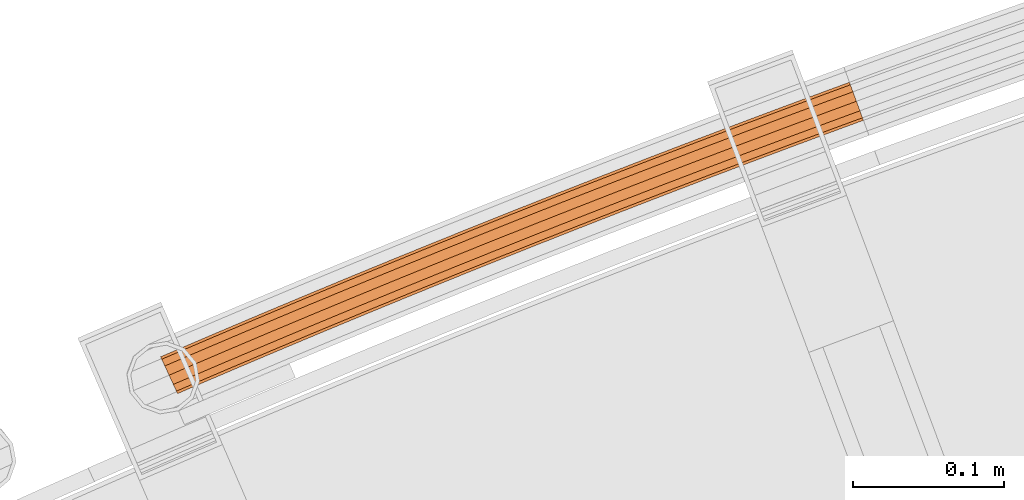
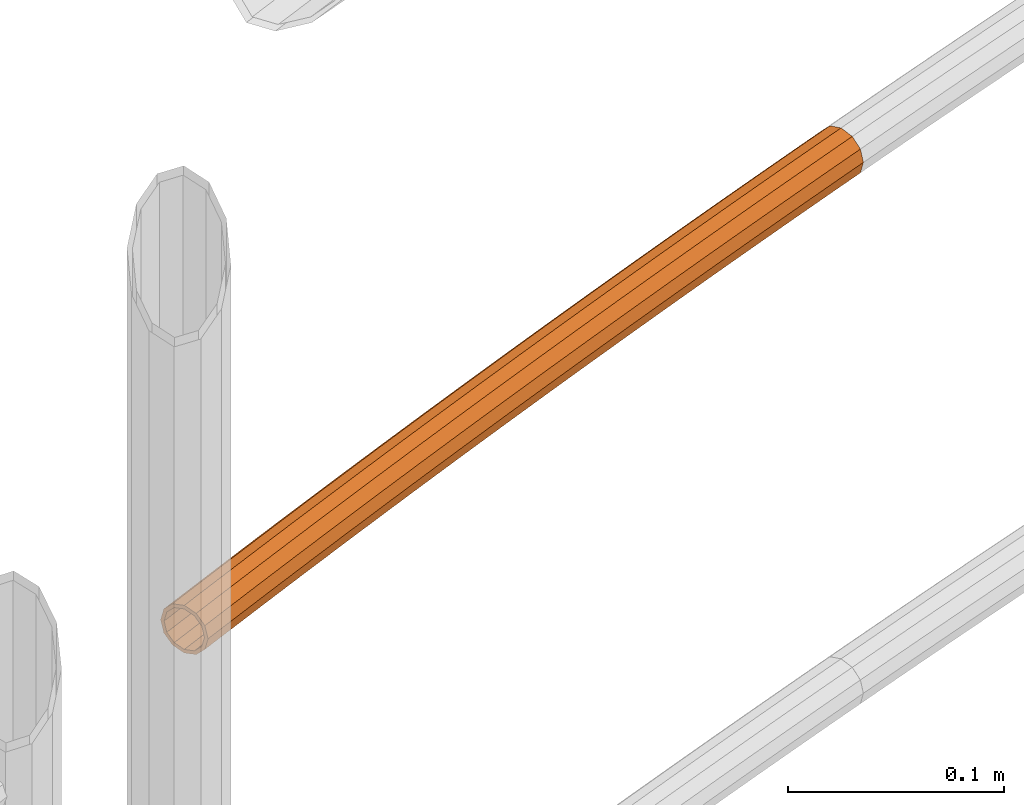
# One storey, part 100 of 126: 1 proxy.
"""IFC2X3 building model written with IfcOpenShell, lengths in millimetres."""

from ifc_helpers import new_model, si_unit, origin, origin_with_axes, place, context, project, spatial, faceted_brep, material, element, save


model = new_model("IFC2X3")

# Units and contexts
context_of_model_1 = context(None, 3, precision=0.1, world=origin())
context_of_model_2 = context(None, 3, precision=0.1, world=origin())
ifc_project = project(units=[si_unit("LENGTHUNIT", "METRE", prefix="MILLI"), si_unit("AREAUNIT", "SQUARE_METRE", prefix="CENTI"), si_unit("VOLUMEUNIT", "CUBIC_METRE", prefix="CENTI"), si_unit("MASSUNIT", "GRAM", prefix="KILO")], contexts=[context_of_model_1, context_of_model_2])

# Site, building, storey
site_placement = place(None, origin_with_axes())
site = spatial("IfcSite", under=ifc_project, at=site_placement, CompositionType="ELEMENT")
building_placement = place(site_placement, origin_with_axes())
building = spatial("IfcBuilding", under=site, at=building_placement, CompositionType="ELEMENT")
storey_placement = place(building_placement, origin_with_axes())
storey = spatial("IfcBuildingStorey", under=building, at=storey_placement, CompositionType="ELEMENT")

# Proxy
ifc_material = material(Name="S235JRG2")
proxy_placement = place(storey_placement, origin_with_axes())
element("IfcBuildingElementProxy", 1, at=proxy_placement, inside=storey, material=ifc_material, context=context_of_model_2, shape_type="Brep", body=[
    faceted_brep([(4502.0995, 16162.147, 11838.155), (4502.8105, 16160.491, 11831.43), (4492.1373, 16155.886, 11831.43), (4491.383, 16157.523, 11838.155), (4504.753, 16155.968, 11826.507), (4494.1982, 16151.413, 11826.507), (4507.4066, 16149.788, 11824.705), (4497.0135, 16145.304, 11824.705), (4510.0602, 16143.609, 11826.507), (4499.8288, 16139.194, 11826.507), (4512.0027, 16139.085, 11831.43), (4501.8897, 16134.722, 11831.43), (4512.7138, 16137.43, 11838.155), (4502.644, 16133.085, 11838.155), (4512.0027, 16139.085, 11844.88), (4501.8897, 16134.722, 11844.88), (4510.0602, 16143.609, 11849.803), (4499.8288, 16139.194, 11849.803), (4507.4066, 16149.788, 11851.605), (4497.0135, 16145.304, 11851.605), (4504.753, 16155.968, 11849.803), (4494.1982, 16151.413, 11849.803), (4502.8105, 16160.491, 11844.88), (4492.1373, 16155.886, 11844.88), (4502.8886, 16160.309, 11838.155), (4503.4939, 16158.9, 11843.88), (4492.8624, 16154.312, 11843.88), (4492.2202, 16155.706, 11838.155), (4505.1476, 16155.049, 11848.071), (4494.6169, 16150.505, 11848.071), (4507.4066, 16149.788, 11849.605), (4497.0135, 16145.304, 11849.605), (4509.6656, 16144.528, 11848.071), (4499.4101, 16140.103, 11848.071), (4511.3193, 16140.677, 11843.88), (4501.1646, 16136.295, 11843.88), (4511.9246, 16139.267, 11838.155), (4501.8068, 16134.902, 11838.155), (4511.3193, 16140.677, 11832.43), (4501.1646, 16136.295, 11832.43), (4509.6656, 16144.528, 11828.239), (4499.4101, 16140.103, 11828.239), (4507.4066, 16149.788, 11826.705), (4497.0135, 16145.304, 11826.705), (4505.1476, 16155.049, 11828.239), (4494.6169, 16150.505, 11828.239), (4503.4939, 16158.9, 11832.43), (4492.8624, 16154.312, 11832.43), (4530.5945, 16174.325, 11838.155), (4531.2998, 16172.666, 11831.43), (4533.2265, 16168.136, 11826.507), (4535.8585, 16161.948, 11824.705), (4538.4905, 16155.759, 11826.507), (4540.4173, 16151.229, 11831.43), (4541.1225, 16149.57, 11838.155), (4540.4173, 16151.229, 11844.88), (4538.4905, 16155.759, 11849.803), (4535.8585, 16161.948, 11851.605), (4533.2265, 16168.136, 11849.803), (4531.2998, 16172.666, 11844.88), (4531.3773, 16172.484, 11838.155), (4531.9777, 16171.073, 11843.88), (4533.6179, 16167.216, 11848.071), (4535.8585, 16161.948, 11849.605), (4538.0992, 16156.679, 11848.071), (4539.7394, 16152.823, 11843.88), (4540.3398, 16151.411, 11838.155), (4539.7394, 16152.823, 11832.43), (4538.0992, 16156.679, 11828.239), (4535.8585, 16161.948, 11826.705), (4533.6179, 16167.216, 11828.239), (4531.9777, 16171.073, 11832.43), (4559.132, 16186.403, 11838.155), (4559.8314, 16184.742, 11831.43), (4561.7424, 16180.205, 11826.507), (4564.3527, 16174.007, 11824.705), (4566.9631, 16167.81, 11826.507), (4568.874, 16163.273, 11831.43), (4569.5735, 16161.612, 11838.155), (4568.874, 16163.273, 11844.88), (4566.9631, 16167.81, 11849.803), (4564.3527, 16174.007, 11851.605), (4561.7424, 16180.205, 11849.803), (4559.8314, 16184.742, 11844.88), (4559.9083, 16184.56, 11838.155), (4560.5037, 16183.146, 11843.88), (4562.1305, 16179.284, 11848.071), (4564.3527, 16174.007, 11849.605), (4566.5749, 16168.731, 11848.071), (4568.2017, 16164.869, 11843.88), (4568.7972, 16163.455, 11838.155), (4568.2017, 16164.869, 11832.43), (4566.5749, 16168.731, 11828.239), (4564.3527, 16174.007, 11826.705), (4562.1305, 16179.284, 11828.239), (4560.5037, 16183.146, 11832.43), (4587.7114, 16198.381, 11838.155), (4588.405, 16196.718, 11831.43), (4590.3001, 16192.174, 11826.507), (4592.8888, 16185.968, 11824.705), (4595.4776, 16179.761, 11826.507), (4597.3726, 16175.217, 11831.43), (4598.0663, 16173.554, 11838.155), (4597.3726, 16175.217, 11844.88), (4595.4776, 16179.761, 11849.803), (4592.8888, 16185.968, 11851.605), (4590.3001, 16192.174, 11849.803), (4588.405, 16196.718, 11844.88), (4588.4813, 16196.535, 11838.155), (4589.0718, 16195.12, 11843.88), (4590.6851, 16191.252, 11848.071), (4592.8888, 16185.968, 11849.605), (4595.0926, 16180.684, 11848.071), (4596.7059, 16176.816, 11843.88), (4597.2964, 16175.4, 11838.155), (4596.7059, 16176.816, 11832.43), (4595.0926, 16180.684, 11828.239), (4592.8888, 16185.968, 11826.705), (4590.6851, 16191.252, 11828.239), (4589.0718, 16195.12, 11832.43), (4616.3325, 16210.26, 11838.155), (4617.0203, 16208.594, 11831.43), (4618.8995, 16204.044, 11826.507), (4621.4665, 16197.828, 11824.705), (4624.0336, 16191.613, 11826.507), (4625.9128, 16187.062, 11831.43), (4626.6006, 16185.397, 11838.155), (4625.9128, 16187.062, 11844.88), (4624.0336, 16191.613, 11849.803), (4621.4665, 16197.828, 11851.605), (4618.8995, 16204.044, 11849.803), (4617.0203, 16208.594, 11844.88), (4617.0959, 16208.411, 11838.155), (4617.6814, 16206.994, 11843.88), (4619.2812, 16203.12, 11848.071), (4621.4665, 16197.828, 11849.605), (4623.6519, 16192.537, 11848.071), (4625.2516, 16188.663, 11843.88), (4625.8372, 16187.245, 11838.155), (4625.2516, 16188.663, 11832.43), (4623.6519, 16192.537, 11828.239), (4621.4665, 16197.828, 11826.705), (4619.2812, 16203.12, 11828.239), (4617.6814, 16206.994, 11832.43), (4644.9948, 16222.039, 11838.155), (4645.6768, 16220.371, 11831.43), (4647.5401, 16215.814, 11826.507), (4650.0855, 16209.589, 11824.705), (4652.6308, 16203.365, 11826.507), (4654.4941, 16198.808, 11831.43), (4655.1761, 16197.14, 11838.155), (4654.4941, 16198.808, 11844.88), (4652.6308, 16203.365, 11849.803), (4650.0855, 16209.589, 11851.605), (4647.5401, 16215.814, 11849.803), (4645.6768, 16220.371, 11844.88), (4645.7518, 16220.187, 11838.155), (4646.3324, 16218.768, 11843.88), (4647.9186, 16214.888, 11848.071), (4650.0855, 16209.589, 11849.605), (4652.2523, 16204.29, 11848.071), (4653.8385, 16200.411, 11843.88), (4654.4191, 16198.991, 11838.155), (4653.8385, 16200.411, 11832.43), (4652.2523, 16204.29, 11828.239), (4650.0855, 16209.589, 11826.705), (4647.9186, 16214.888, 11828.239), (4646.3324, 16218.768, 11832.43), (4673.6981, 16233.717, 11838.155), (4674.3743, 16232.047, 11831.43), (4676.2217, 16227.484, 11826.507), (4678.7453, 16221.25, 11824.705), (4681.2688, 16215.017, 11826.507), (4683.1162, 16210.453, 11831.43), (4683.7924, 16208.783, 11838.155), (4683.1162, 16210.453, 11844.88), (4681.2688, 16215.017, 11849.803), (4678.7453, 16221.25, 11851.605), (4676.2217, 16227.484, 11849.803), (4674.3743, 16232.047, 11844.88), (4674.4486, 16231.863, 11838.155), (4675.0242, 16230.441, 11843.88), (4676.5969, 16226.557, 11848.071), (4678.7453, 16221.25, 11849.605), (4680.8936, 16215.943, 11848.071), (4682.4663, 16212.059, 11843.88), (4683.0419, 16210.637, 11838.155), (4682.4663, 16212.059, 11832.43), (4680.8936, 16215.943, 11828.239), (4678.7453, 16221.25, 11826.705), (4676.5969, 16226.557, 11828.239), (4675.0242, 16230.441, 11832.43), (4702.442, 16245.295, 11838.155), (4703.1123, 16243.623, 11831.43), (4704.9438, 16239.053, 11826.507), (4707.4456, 16232.811, 11824.705), (4709.9474, 16226.568, 11826.507), (4711.7789, 16221.999, 11831.43), (4712.4492, 16220.326, 11838.155), (4711.7789, 16221.999, 11844.88), (4709.9474, 16226.568, 11849.803), (4707.4456, 16232.811, 11851.605), (4704.9438, 16239.053, 11849.803), (4703.1123, 16243.623, 11844.88), (4703.186, 16243.439, 11838.155), (4703.7567, 16242.015, 11843.88), (4705.3158, 16238.125, 11848.071), (4707.4456, 16232.811, 11849.605), (4709.5754, 16227.497, 11848.071), (4711.1345, 16223.607, 11843.88), (4711.7052, 16222.183, 11838.155), (4711.1345, 16223.607, 11832.43), (4709.5754, 16227.497, 11828.239), (4707.4456, 16232.811, 11826.705), (4705.3158, 16238.125, 11828.239), (4703.7567, 16242.015, 11832.43), (4731.2261, 16256.773, 11838.155), (4731.8906, 16255.098, 11831.43), (4733.7061, 16250.522, 11826.507), (4736.1861, 16244.271, 11824.705), (4738.6661, 16238.02, 11826.507), (4740.4816, 16233.444, 11831.43), (4741.1461, 16231.769, 11838.155), (4740.4816, 16233.444, 11844.88), (4738.6661, 16238.02, 11849.803), (4736.1861, 16244.271, 11851.605), (4733.7061, 16250.522, 11849.803), (4731.8906, 16255.098, 11844.88), (4731.9636, 16254.914, 11838.155), (4732.5293, 16253.488, 11843.88), (4734.0749, 16249.593, 11848.071), (4736.1861, 16244.271, 11849.605), (4738.2973, 16238.95, 11848.071), (4739.8429, 16235.054, 11843.88), (4740.4086, 16233.628, 11838.155), (4739.8429, 16235.054, 11832.43), (4738.2973, 16238.95, 11828.239), (4736.1861, 16244.271, 11826.705), (4734.0749, 16249.593, 11828.239), (4732.5293, 16253.488, 11832.43), (4760.0501, 16268.151, 11838.155), (4760.7088, 16266.473, 11831.43), (4762.5083, 16261.891, 11826.507), (4764.9664, 16255.631, 11824.705), (4767.4246, 16249.372, 11826.507), (4769.2241, 16244.789, 11831.43), (4769.8828, 16243.112, 11838.155), (4769.2241, 16244.789, 11844.88), (4767.4246, 16249.372, 11849.803), (4764.9664, 16255.631, 11851.605), (4762.5083, 16261.891, 11849.803), (4760.7088, 16266.473, 11844.88), (4760.7812, 16266.289, 11838.155), (4761.3419, 16264.861, 11843.88), (4762.8738, 16260.96, 11848.071), (4764.9664, 16255.631, 11849.605), (4767.0591, 16250.303, 11848.071), (4768.591, 16246.402, 11843.88), (4769.1517, 16244.974, 11838.155), (4768.591, 16246.402, 11832.43), (4767.0591, 16250.303, 11828.239), (4764.9664, 16255.631, 11826.705), (4762.8738, 16260.96, 11828.239), (4761.3419, 16264.861, 11832.43), (4788.9136, 16279.427, 11838.155), (4789.5665, 16277.748, 11831.43), (4791.35, 16273.159, 11826.507), (4793.7863, 16266.891, 11824.705), (4796.2226, 16260.623, 11826.507), (4798.0061, 16256.034, 11831.43), (4798.6589, 16254.354, 11838.155), (4798.0061, 16256.034, 11844.88), (4796.2226, 16260.623, 11849.803), (4793.7863, 16266.891, 11851.605), (4791.35, 16273.159, 11849.803), (4789.5665, 16277.748, 11844.88), (4789.6382, 16277.563, 11838.155), (4790.1939, 16276.133, 11843.88), (4791.7122, 16272.227, 11848.071), (4793.7863, 16266.891, 11849.605), (4795.8603, 16261.555, 11848.071), (4797.3786, 16257.648, 11843.88), (4797.9343, 16256.219, 11838.155), (4797.3786, 16257.648, 11832.43), (4795.8603, 16261.555, 11828.239), (4793.7863, 16266.891, 11826.705), (4791.7122, 16272.227, 11828.239), (4790.1939, 16276.133, 11832.43), (4817.8164, 16290.603, 11838.155), (4818.4633, 16288.921, 11831.43), (4820.2308, 16284.326, 11826.507), (4822.6452, 16278.05, 11824.705), (4825.0596, 16271.773, 11826.507), (4826.8271, 16267.178, 11831.43), (4827.474, 16265.496, 11838.155), (4826.8271, 16267.178, 11844.88), (4825.0596, 16271.773, 11849.803), (4822.6452, 16278.05, 11851.605), (4820.2308, 16284.326, 11849.803), (4818.4633, 16288.921, 11844.88), (4818.5344, 16288.737, 11838.155), (4819.0852, 16287.305, 11843.88), (4820.5898, 16283.393, 11848.071), (4822.6452, 16278.05, 11849.605), (4824.7006, 16272.707, 11848.071), (4826.2052, 16268.795, 11843.88), (4826.756, 16267.363, 11838.155), (4826.2052, 16268.795, 11832.43), (4824.7006, 16272.707, 11828.239), (4822.6452, 16278.05, 11826.705), (4820.5898, 16283.393, 11828.239), (4819.0852, 16287.305, 11832.43), (4846.758, 16301.678, 11838.155), (4847.399, 16299.994, 11831.43), (4849.1504, 16295.393, 11826.507), (4851.5429, 16289.108, 11824.705), (4853.9354, 16282.823, 11826.507), (4855.6868, 16278.222, 11831.43), (4856.3279, 16276.538, 11838.155), (4855.6868, 16278.222, 11844.88), (4853.9354, 16282.823, 11849.803), (4851.5429, 16289.108, 11851.605), (4849.1504, 16295.393, 11849.803), (4847.399, 16299.994, 11844.88), (4847.4695, 16299.809, 11838.155), (4848.0152, 16298.375, 11843.88), (4849.5062, 16294.458, 11848.071), (4851.5429, 16289.108, 11849.605), (4853.5797, 16283.757, 11848.071), (4855.0706, 16279.841, 11843.88), (4855.6164, 16278.407, 11838.155), (4855.0706, 16279.841, 11832.43), (4853.5797, 16283.757, 11828.239), (4851.5429, 16289.108, 11826.705), (4849.5062, 16294.458, 11828.239), (4848.0152, 16298.375, 11832.43), (4875.738, 16312.652, 11838.155), (4876.3732, 16310.966, 11831.43), (4878.1085, 16306.358, 11826.507), (4880.4791, 16300.065, 11824.705), (4882.8496, 16293.772, 11826.507), (4884.585, 16289.165, 11831.43), (4885.2201, 16287.478, 11838.155), (4884.585, 16289.165, 11844.88), (4882.8496, 16293.772, 11849.803), (4880.4791, 16300.065, 11851.605), (4878.1085, 16306.358, 11849.803), (4876.3732, 16310.966, 11844.88), (4876.443, 16310.78, 11838.155), (4876.9837, 16309.345, 11843.88), (4878.461, 16305.423, 11848.071), (4880.4791, 16300.065, 11849.605), (4882.4971, 16294.708, 11848.071), (4883.9744, 16290.786, 11843.88), (4884.5151, 16289.35, 11838.155), (4883.9744, 16290.786, 11832.43), (4882.4971, 16294.708, 11828.239), (4880.4791, 16300.065, 11826.705), (4878.461, 16305.423, 11828.239), (4876.9837, 16309.345, 11832.43), (4904.7562, 16323.524, 11838.155), (4905.3855, 16321.836, 11831.43), (4907.1047, 16317.223, 11826.507), (4909.4533, 16310.921, 11824.705), (4911.8018, 16304.62, 11826.507), (4913.5211, 16300.007, 11831.43), (4914.1504, 16298.318, 11838.155), (4913.5211, 16300.007, 11844.88), (4911.8018, 16304.62, 11849.803), (4909.4533, 16310.921, 11851.605), (4907.1047, 16317.223, 11849.803), (4905.3855, 16321.836, 11844.88), (4905.4546, 16321.65, 11838.155), (4905.9904, 16320.213, 11843.88), (4907.454, 16316.286, 11848.071), (4909.4533, 16310.921, 11849.605), (4911.4526, 16305.557, 11848.071), (4912.9162, 16301.629, 11843.88), (4913.4519, 16300.192, 11838.155), (4912.9162, 16301.629, 11832.43), (4911.4526, 16305.557, 11828.239), (4909.4533, 16310.921, 11826.705), (4907.454, 16316.286, 11828.239), (4905.9904, 16320.213, 11832.43), (4933.8121, 16334.296, 11838.155), (4934.4355, 16332.605, 11831.43), (4936.1387, 16327.986, 11826.507), (4938.4652, 16321.676, 11824.705), (4940.7918, 16315.366, 11826.507), (4942.4949, 16310.747, 11831.43), (4943.1183, 16309.057, 11838.155), (4942.4949, 16310.747, 11844.88), (4940.7918, 16315.366, 11849.803), (4938.4652, 16321.676, 11851.605), (4936.1387, 16327.986, 11849.803), (4934.4355, 16332.605, 11844.88), (4934.504, 16332.419, 11838.155), (4935.0347, 16330.98, 11843.88), (4936.4846, 16327.048, 11848.071), (4938.4652, 16321.676, 11849.605), (4940.4458, 16316.305, 11848.071), (4941.8957, 16312.372, 11843.88), (4942.4264, 16310.933, 11838.155), (4941.8957, 16312.372, 11832.43), (4940.4458, 16316.305, 11828.239), (4938.4652, 16321.676, 11826.705), (4936.4846, 16327.048, 11828.239), (4935.0347, 16330.98, 11832.43), (4948.3572, 16339.63, 11838.155), (4948.9777, 16337.938, 11831.43), (4950.6729, 16333.316, 11826.507), (4952.9886, 16327.002, 11824.705), (4955.3043, 16320.689, 11826.507), (4956.9995, 16316.067, 11831.43), (4957.62, 16314.375, 11838.155), (4956.9995, 16316.067, 11844.88), (4955.3043, 16320.689, 11849.803), (4952.9886, 16327.002, 11851.605), (4950.6729, 16333.316, 11849.803), (4948.9777, 16337.938, 11844.88), (4949.0459, 16337.752, 11838.155), (4949.5741, 16336.312, 11843.88), (4951.0173, 16332.377, 11848.071), (4952.9886, 16327.002, 11849.605), (4954.96, 16321.627, 11848.071), (4956.4031, 16317.693, 11843.88), (4956.9313, 16316.253, 11838.155), (4956.4031, 16317.693, 11832.43), (4954.96, 16321.627, 11828.239), (4952.9886, 16327.002, 11826.705), (4951.0173, 16332.377, 11828.239), (4949.5741, 16336.312, 11832.43)], [[[0, 1, 2, 3]], [[1, 4, 5, 2]], [[4, 6, 7, 5]], [[6, 8, 9, 7]], [[8, 10, 11, 9]], [[10, 12, 13, 11]], [[12, 14, 15, 13]], [[14, 16, 17, 15]], [[16, 18, 19, 17]], [[18, 20, 21, 19]], [[20, 22, 23, 21]], [[0, 3, 23, 22]], [[24, 25, 26, 27]], [[25, 28, 29, 26]], [[28, 30, 31, 29]], [[30, 32, 33, 31]], [[32, 34, 35, 33]], [[34, 36, 37, 35]], [[36, 38, 39, 37]], [[38, 40, 41, 39]], [[40, 42, 43, 41]], [[42, 44, 45, 43]], [[44, 46, 47, 45]], [[24, 27, 47, 46]], [[0, 48, 49, 1]], [[1, 49, 50, 4]], [[4, 50, 51, 6]], [[6, 51, 52, 8]], [[8, 52, 53, 10]], [[10, 53, 54, 12]], [[12, 54, 55, 14]], [[14, 55, 56, 16]], [[16, 56, 57, 18]], [[18, 57, 58, 20]], [[20, 58, 59, 22]], [[22, 59, 48, 0]], [[24, 60, 61, 25]], [[25, 61, 62, 28]], [[28, 62, 63, 30]], [[30, 63, 64, 32]], [[32, 64, 65, 34]], [[34, 65, 66, 36]], [[36, 66, 67, 38]], [[38, 67, 68, 40]], [[40, 68, 69, 42]], [[42, 69, 70, 44]], [[44, 70, 71, 46]], [[46, 71, 60, 24]], [[48, 72, 73, 49]], [[49, 73, 74, 50]], [[50, 74, 75, 51]], [[51, 75, 76, 52]], [[52, 76, 77, 53]], [[53, 77, 78, 54]], [[54, 78, 79, 55]], [[55, 79, 80, 56]], [[56, 80, 81, 57]], [[57, 81, 82, 58]], [[58, 82, 83, 59]], [[59, 83, 72, 48]], [[60, 84, 85, 61]], [[61, 85, 86, 62]], [[62, 86, 87, 63]], [[63, 87, 88, 64]], [[64, 88, 89, 65]], [[65, 89, 90, 66]], [[66, 90, 91, 67]], [[67, 91, 92, 68]], [[68, 92, 93, 69]], [[69, 93, 94, 70]], [[70, 94, 95, 71]], [[71, 95, 84, 60]], [[72, 96, 97, 73]], [[73, 97, 98, 74]], [[74, 98, 99, 75]], [[75, 99, 100, 76]], [[76, 100, 101, 77]], [[77, 101, 102, 78]], [[78, 102, 103, 79]], [[79, 103, 104, 80]], [[80, 104, 105, 81]], [[81, 105, 106, 82]], [[82, 106, 107, 83]], [[83, 107, 96, 72]], [[84, 108, 109, 85]], [[85, 109, 110, 86]], [[86, 110, 111, 87]], [[87, 111, 112, 88]], [[88, 112, 113, 89]], [[89, 113, 114, 90]], [[90, 114, 115, 91]], [[91, 115, 116, 92]], [[92, 116, 117, 93]], [[93, 117, 118, 94]], [[94, 118, 119, 95]], [[95, 119, 108, 84]], [[96, 120, 121, 97]], [[97, 121, 122, 98]], [[98, 122, 123, 99]], [[99, 123, 124, 100]], [[100, 124, 125, 101]], [[101, 125, 126, 102]], [[102, 126, 127, 103]], [[103, 127, 128, 104]], [[104, 128, 129, 105]], [[105, 129, 130, 106]], [[106, 130, 131, 107]], [[107, 131, 120, 96]], [[108, 132, 133, 109]], [[109, 133, 134, 110]], [[110, 134, 135, 111]], [[111, 135, 136, 112]], [[112, 136, 137, 113]], [[113, 137, 138, 114]], [[114, 138, 139, 115]], [[115, 139, 140, 116]], [[116, 140, 141, 117]], [[117, 141, 142, 118]], [[118, 142, 143, 119]], [[119, 143, 132, 108]], [[120, 144, 145, 121]], [[121, 145, 146, 122]], [[122, 146, 147, 123]], [[123, 147, 148, 124]], [[124, 148, 149, 125]], [[125, 149, 150, 126]], [[126, 150, 151, 127]], [[127, 151, 152, 128]], [[128, 152, 153, 129]], [[129, 153, 154, 130]], [[130, 154, 155, 131]], [[131, 155, 144, 120]], [[132, 156, 157, 133]], [[133, 157, 158, 134]], [[134, 158, 159, 135]], [[135, 159, 160, 136]], [[136, 160, 161, 137]], [[137, 161, 162, 138]], [[138, 162, 163, 139]], [[139, 163, 164, 140]], [[140, 164, 165, 141]], [[141, 165, 166, 142]], [[142, 166, 167, 143]], [[143, 167, 156, 132]], [[144, 168, 169, 145]], [[145, 169, 170, 146]], [[146, 170, 171, 147]], [[147, 171, 172, 148]], [[148, 172, 173, 149]], [[149, 173, 174, 150]], [[150, 174, 175, 151]], [[151, 175, 176, 152]], [[152, 176, 177, 153]], [[153, 177, 178, 154]], [[154, 178, 179, 155]], [[155, 179, 168, 144]], [[156, 180, 181, 157]], [[157, 181, 182, 158]], [[158, 182, 183, 159]], [[159, 183, 184, 160]], [[160, 184, 185, 161]], [[161, 185, 186, 162]], [[162, 186, 187, 163]], [[163, 187, 188, 164]], [[164, 188, 189, 165]], [[165, 189, 190, 166]], [[166, 190, 191, 167]], [[167, 191, 180, 156]], [[168, 192, 193, 169]], [[169, 193, 194, 170]], [[170, 194, 195, 171]], [[171, 195, 196, 172]], [[172, 196, 197, 173]], [[173, 197, 198, 174]], [[174, 198, 199, 175]], [[175, 199, 200, 176]], [[176, 200, 201, 177]], [[177, 201, 202, 178]], [[178, 202, 203, 179]], [[179, 203, 192, 168]], [[180, 204, 205, 181]], [[181, 205, 206, 182]], [[182, 206, 207, 183]], [[183, 207, 208, 184]], [[184, 208, 209, 185]], [[185, 209, 210, 186]], [[186, 210, 211, 187]], [[187, 211, 212, 188]], [[188, 212, 213, 189]], [[189, 213, 214, 190]], [[190, 214, 215, 191]], [[191, 215, 204, 180]], [[192, 216, 217, 193]], [[193, 217, 218, 194]], [[194, 218, 219, 195]], [[195, 219, 220, 196]], [[196, 220, 221, 197]], [[197, 221, 222, 198]], [[198, 222, 223, 199]], [[199, 223, 224, 200]], [[200, 224, 225, 201]], [[201, 225, 226, 202]], [[202, 226, 227, 203]], [[203, 227, 216, 192]], [[204, 228, 229, 205]], [[205, 229, 230, 206]], [[206, 230, 231, 207]], [[207, 231, 232, 208]], [[208, 232, 233, 209]], [[209, 233, 234, 210]], [[210, 234, 235, 211]], [[211, 235, 236, 212]], [[212, 236, 237, 213]], [[213, 237, 238, 214]], [[214, 238, 239, 215]], [[215, 239, 228, 204]], [[216, 240, 241, 217]], [[217, 241, 242, 218]], [[218, 242, 243, 219]], [[219, 243, 244, 220]], [[220, 244, 245, 221]], [[221, 245, 246, 222]], [[222, 246, 247, 223]], [[223, 247, 248, 224]], [[224, 248, 249, 225]], [[225, 249, 250, 226]], [[226, 250, 251, 227]], [[227, 251, 240, 216]], [[228, 252, 253, 229]], [[229, 253, 254, 230]], [[230, 254, 255, 231]], [[231, 255, 256, 232]], [[232, 256, 257, 233]], [[233, 257, 258, 234]], [[234, 258, 259, 235]], [[235, 259, 260, 236]], [[236, 260, 261, 237]], [[237, 261, 262, 238]], [[238, 262, 263, 239]], [[239, 263, 252, 228]], [[240, 264, 265, 241]], [[241, 265, 266, 242]], [[242, 266, 267, 243]], [[243, 267, 268, 244]], [[244, 268, 269, 245]], [[245, 269, 270, 246]], [[246, 270, 271, 247]], [[247, 271, 272, 248]], [[248, 272, 273, 249]], [[249, 273, 274, 250]], [[250, 274, 275, 251]], [[251, 275, 264, 240]], [[252, 276, 277, 253]], [[253, 277, 278, 254]], [[254, 278, 279, 255]], [[255, 279, 280, 256]], [[256, 280, 281, 257]], [[257, 281, 282, 258]], [[258, 282, 283, 259]], [[259, 283, 284, 260]], [[260, 284, 285, 261]], [[261, 285, 286, 262]], [[262, 286, 287, 263]], [[263, 287, 276, 252]], [[264, 288, 289, 265]], [[265, 289, 290, 266]], [[266, 290, 291, 267]], [[267, 291, 292, 268]], [[268, 292, 293, 269]], [[269, 293, 294, 270]], [[270, 294, 295, 271]], [[271, 295, 296, 272]], [[272, 296, 297, 273]], [[273, 297, 298, 274]], [[274, 298, 299, 275]], [[275, 299, 288, 264]], [[276, 300, 301, 277]], [[277, 301, 302, 278]], [[278, 302, 303, 279]], [[279, 303, 304, 280]], [[280, 304, 305, 281]], [[281, 305, 306, 282]], [[282, 306, 307, 283]], [[283, 307, 308, 284]], [[284, 308, 309, 285]], [[285, 309, 310, 286]], [[286, 310, 311, 287]], [[287, 311, 300, 276]], [[288, 312, 313, 289]], [[289, 313, 314, 290]], [[290, 314, 315, 291]], [[291, 315, 316, 292]], [[292, 316, 317, 293]], [[293, 317, 318, 294]], [[294, 318, 319, 295]], [[295, 319, 320, 296]], [[296, 320, 321, 297]], [[297, 321, 322, 298]], [[298, 322, 323, 299]], [[299, 323, 312, 288]], [[300, 324, 325, 301]], [[301, 325, 326, 302]], [[302, 326, 327, 303]], [[303, 327, 328, 304]], [[304, 328, 329, 305]], [[305, 329, 330, 306]], [[306, 330, 331, 307]], [[307, 331, 332, 308]], [[308, 332, 333, 309]], [[309, 333, 334, 310]], [[310, 334, 335, 311]], [[311, 335, 324, 300]], [[312, 336, 337, 313]], [[313, 337, 338, 314]], [[314, 338, 339, 315]], [[315, 339, 340, 316]], [[316, 340, 341, 317]], [[317, 341, 342, 318]], [[318, 342, 343, 319]], [[319, 343, 344, 320]], [[320, 344, 345, 321]], [[321, 345, 346, 322]], [[322, 346, 347, 323]], [[323, 347, 336, 312]], [[324, 348, 349, 325]], [[325, 349, 350, 326]], [[326, 350, 351, 327]], [[327, 351, 352, 328]], [[328, 352, 353, 329]], [[329, 353, 354, 330]], [[330, 354, 355, 331]], [[331, 355, 356, 332]], [[332, 356, 357, 333]], [[333, 357, 358, 334]], [[334, 358, 359, 335]], [[335, 359, 348, 324]], [[336, 360, 361, 337]], [[337, 361, 362, 338]], [[338, 362, 363, 339]], [[339, 363, 364, 340]], [[340, 364, 365, 341]], [[341, 365, 366, 342]], [[342, 366, 367, 343]], [[343, 367, 368, 344]], [[344, 368, 369, 345]], [[345, 369, 370, 346]], [[346, 370, 371, 347]], [[347, 371, 360, 336]], [[348, 372, 373, 349]], [[349, 373, 374, 350]], [[350, 374, 375, 351]], [[351, 375, 376, 352]], [[352, 376, 377, 353]], [[353, 377, 378, 354]], [[354, 378, 379, 355]], [[355, 379, 380, 356]], [[356, 380, 381, 357]], [[357, 381, 382, 358]], [[358, 382, 383, 359]], [[359, 383, 372, 348]], [[360, 384, 385, 361]], [[361, 385, 386, 362]], [[362, 386, 387, 363]], [[363, 387, 388, 364]], [[364, 388, 389, 365]], [[365, 389, 390, 366]], [[366, 390, 391, 367]], [[367, 391, 392, 368]], [[368, 392, 393, 369]], [[369, 393, 394, 370]], [[370, 394, 395, 371]], [[371, 395, 384, 360]], [[372, 396, 397, 373]], [[373, 397, 398, 374]], [[374, 398, 399, 375]], [[375, 399, 400, 376]], [[376, 400, 401, 377]], [[377, 401, 402, 378]], [[378, 402, 403, 379]], [[379, 403, 404, 380]], [[380, 404, 405, 381]], [[381, 405, 406, 382]], [[382, 406, 407, 383]], [[383, 407, 396, 372]], [[384, 408, 409, 385]], [[385, 409, 410, 386]], [[386, 410, 411, 387]], [[387, 411, 412, 388]], [[388, 412, 413, 389]], [[389, 413, 414, 390]], [[390, 414, 415, 391]], [[391, 415, 416, 392]], [[392, 416, 417, 393]], [[393, 417, 418, 394]], [[394, 418, 419, 395]], [[384, 395, 419, 408]], [[396, 420, 421, 397]], [[397, 421, 422, 398]], [[398, 422, 423, 399]], [[399, 423, 424, 400]], [[400, 424, 425, 401]], [[401, 425, 426, 402]], [[402, 426, 427, 403]], [[403, 427, 428, 404]], [[404, 428, 429, 405]], [[405, 429, 430, 406]], [[406, 430, 431, 407]], [[396, 407, 431, 420]], [[7, 9, 11, 13, 15, 17, 19, 21, 23, 3, 2, 5], [26, 29, 31, 33, 35, 37, 39, 41, 43, 45, 47, 27]], [[414, 413, 412, 411, 410, 409, 408, 419, 418, 417, 416, 415], [420, 431, 430, 429, 428, 427, 426, 425, 424, 423, 422, 421]]]),
])

save(model, "model.ifc")
